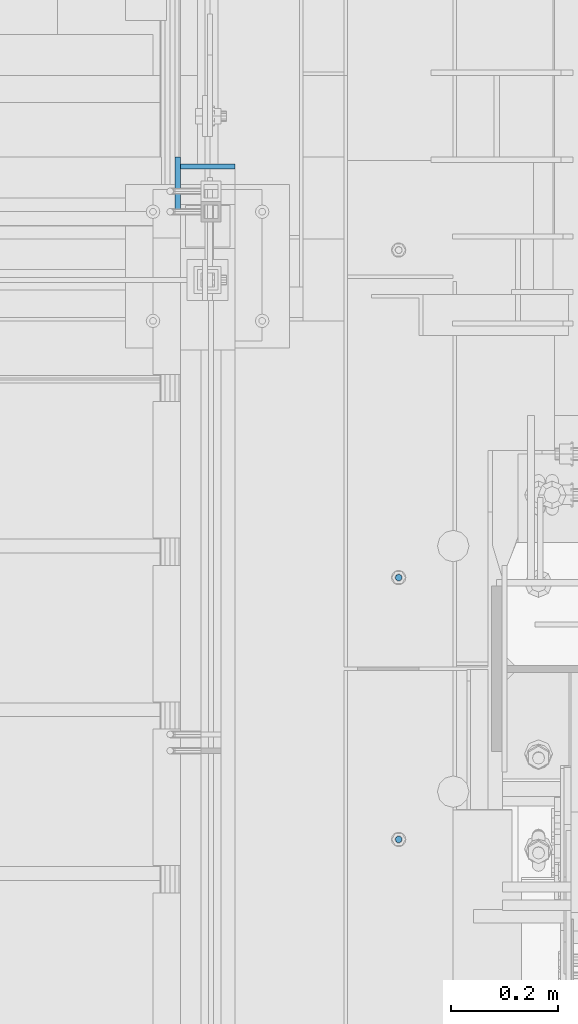
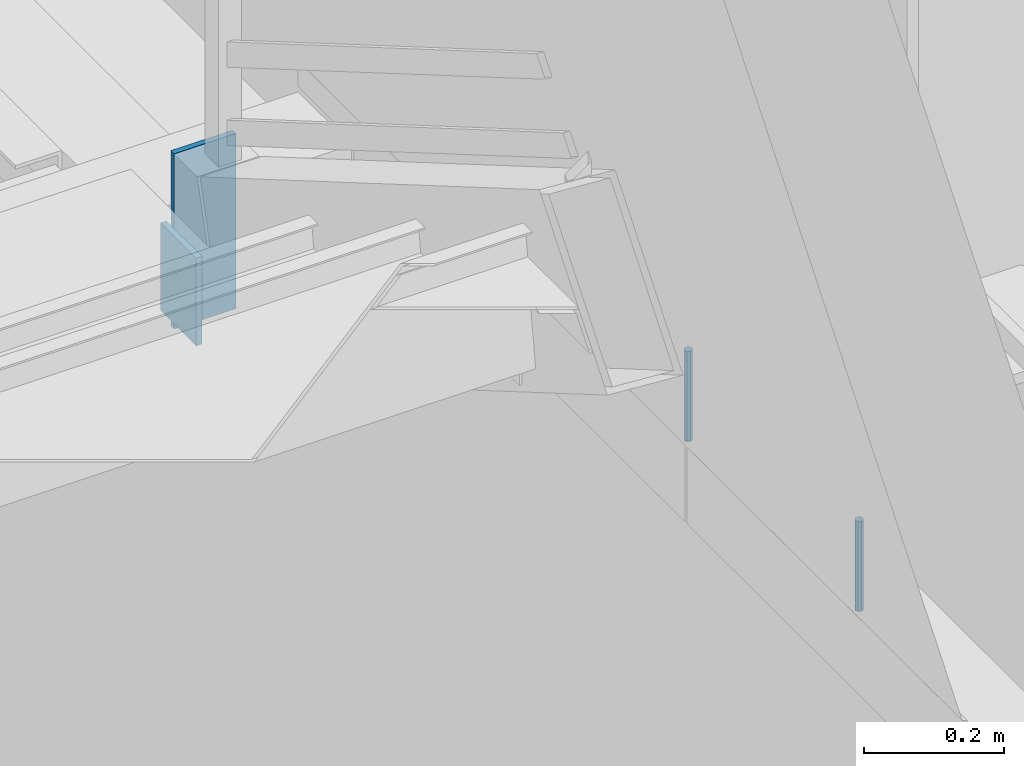
# One storey, part 491 of 1179: 4 columns, 4 elements without a shape of their own.
"""IFC2X3 building model written with IfcOpenShell, lengths in millimetres."""

from ifc_helpers import new_model, si_unit, frame, origin_with_axes, place, context, subcontext, project, spatial, faceted_brep, material, type_object, element, aggregate, save


model = new_model("IFC2X3")

# Units and contexts
model_context = context("Model", 3, precision=1e-05, world=origin_with_axes())
body_context = subcontext(model_context, "Body", "Model", "MODEL_VIEW")
ifc_project = project(units=[si_unit("LENGTHUNIT", "METRE", prefix="MILLI"), si_unit("AREAUNIT", "SQUARE_METRE"), si_unit("VOLUMEUNIT", "CUBIC_METRE"), si_unit("MASSUNIT", "GRAM", prefix="KILO"), si_unit("TIMEUNIT", "SECOND"), si_unit("PLANEANGLEUNIT", "RADIAN"), si_unit("SOLIDANGLEUNIT", "STERADIAN"), si_unit("THERMODYNAMICTEMPERATUREUNIT", "DEGREE_CELSIUS"), si_unit("LUMINOUSINTENSITYUNIT", "LUMEN")], contexts=[model_context])

# Site, building, storey
site_placement = place(None, origin_with_axes())
site = spatial("IfcSite", under=ifc_project, at=site_placement, CompositionType="ELEMENT")
building_placement = place(site_placement, origin_with_axes())
building = spatial("IfcBuilding", under=site, at=building_placement, Name="Undefined", CompositionType="ELEMENT")
storey_placement = place(building_placement, origin_with_axes())
storey = spatial("IfcBuildingStorey", under=building, at=storey_placement, Name="Undefined", CompositionType="ELEMENT", Elevation=0.0)

# Assembly, column
assembly_1_placement = place(storey_placement, origin_with_axes())
assembly_1 = element("IfcElementAssembly", 1, at=assembly_1_placement, inside=storey, Name="BEAM", AssemblyPlace="NOTDEFINED", PredefinedType="RIGID_FRAME")
ifc_material_1 = material(Name="STEEL/A36")
column_type_1 = type_object("IfcColumnType", PredefinedType="NOTDEFINED")
column_1_placement = place(assembly_1_placement, frame((-309.562499975601, 35293.3000000027, 4003.67499999882), z_axis=(0.0, 1.0, 0.0), x_axis=(0.0, 0.0, 1.0)))
column_1 = element("IfcColumn", 2, at=column_1_placement, type_object=column_type_1, material=ifc_material_1, Name="PLATE", context=body_context, shape_type="Brep", body=[
    faceted_brep([(0.0, 4.76249999999982, -50.7999999999993), (0.0, 4.76249999999982, 50.7999999999993), (152.399999999999, 4.76249999999999, 50.8000000000029), (152.399999999999, 4.76249999999999, -50.8000000000029), (0.0, -4.76249999999982, 50.7999999999993), (152.399999999999, -4.76249999999999, 50.8000000000029), (0.0, -4.76249999999982, -50.7999999999993), (152.399999999999, -4.76249999999999, -50.8000000000029)], [[[0, 1, 2, 3]], [[1, 4, 5, 2]], [[4, 6, 7, 5]], [[6, 0, 3, 7]], [[5, 7, 3, 2]], [[6, 4, 1, 0]]]),
])
aggregate(assembly_1, [column_1])

assembly_2_placement = place(storey_placement, origin_with_axes())
assembly_2 = element("IfcElementAssembly", 3, at=assembly_2_placement, inside=storey, Name="STRINGER", AssemblyPlace="NOTDEFINED", PredefinedType="RIGID_FRAME")
column_2_placement = place(assembly_2_placement, frame((-253.999999998673, 35326.6375000028, 3981.4499989016), z_axis=(1.0, 0.0, 0.0), x_axis=(0.0, 0.0, 1.0)))
column_2 = element("IfcColumn", 4, at=column_2_placement, type_object=column_type_1, material=ifc_material_1, Name="PLATE", context=body_context, shape_type="Brep", body=[
    faceted_brep([(0.0, 4.76249999999982, -50.7999999999993), (0.0, 4.76249999999982, 50.7999999999993), (304.799999999999, 4.76249999999709, 50.8), (304.799999999999, 4.76249999999709, -50.8), (0.0, -4.76249999999982, 50.7999999999993), (304.799999999999, -4.76249999999709, 50.8), (0.0, -4.76249999999982, -50.7999999999993), (304.799999999999, -4.76249999999709, -50.8)], [[[0, 1, 2, 3]], [[1, 4, 5, 2]], [[4, 6, 7, 5]], [[6, 0, 3, 7]], [[5, 7, 3, 2]], [[6, 4, 1, 0]]]),
])
aggregate(assembly_2, [column_2])

assembly_3_placement = place(storey_placement, origin_with_axes())
assembly_3 = element("IfcElementAssembly", 5, at=assembly_3_placement, inside=storey, Name="BEAM", AssemblyPlace="NOTDEFINED", PredefinedType="RIGID_FRAME")
ifc_material_2 = material(Name="STEEL/A307")
column_type_2 = type_object("IfcColumnType", PredefinedType="NOTDEFINED")
column_3_placement = place(assembly_3_placement, frame((101.600000333522, 34561.4624998706, 4108.45), z_axis=(0.0, 1.0, 0.0), x_axis=(0.0, 0.0, 1.0)))
column_3 = element("IfcColumn", 6, at=column_3_placement, type_object=column_type_2, material=ifc_material_2, Name="THREADED ROD", context=body_context, shape_type="Brep", body=[
    faceted_brep([(0.0, -6.34999999999854, 0.0), (0.0, -4.49012806053361, -4.49012806053452), (157.162499999999, -4.49012806053361, -4.49012806053361), (157.162499999999, -6.34999999999854, 0.0), (0.0, 0.0, -6.34999999999991), (157.162499999999, 0.0, -6.34999999999854), (0.0, 4.49012806053361, -4.49012806053452), (157.162499999999, 4.49012806053361, -4.49012806053361), (0.0, 6.34999999999854, 0.0), (157.162499999999, 6.34999999999854, 0.0), (0.0, 4.49012806053361, 4.49012806053452), (157.162499999999, 4.49012806053361, 4.49012806053361), (0.0, 0.0, 6.34999999999991), (157.162499999999, 0.0, 6.34999999999854), (0.0, -4.49012806053361, 4.49012806053452), (157.162499999999, -4.49012806053361, 4.49012806053361)], [[[0, 1, 2, 3]], [[1, 4, 5, 2]], [[4, 6, 7, 5]], [[6, 8, 9, 7]], [[8, 10, 11, 9]], [[10, 12, 13, 11]], [[12, 14, 15, 13]], [[14, 0, 3, 15]], [[5, 7, 9, 11, 13, 15, 3, 2]], [[14, 12, 10, 8, 6, 4, 1, 0]]]),
])
aggregate(assembly_3, [column_3])

assembly_4_placement = place(storey_placement, origin_with_axes())
assembly_4 = element("IfcElementAssembly", 7, at=assembly_4_placement, inside=storey, Name="BEAM", AssemblyPlace="NOTDEFINED", PredefinedType="RIGID_FRAME")
column_4_placement = place(assembly_4_placement, frame((101.599999999999, 34074.10025, 4108.45), z_axis=(0.0, 1.0, 0.0), x_axis=(0.0, 0.0, 1.0)))
column_4 = element("IfcColumn", 8, at=column_4_placement, type_object=column_type_2, material=ifc_material_2, Name="THREADED ROD", context=body_context, shape_type="Brep", body=[
    faceted_brep([(0.0, -6.34999999999854, 0.0), (0.0, -4.49012806053361, -4.49012806053452), (157.162499999999, -4.49012806053361, -4.49012806053361), (157.162499999999, -6.34999999999854, 0.0), (0.0, 0.0, -6.34999999999991), (157.162499999999, 0.0, -6.34999999999854), (0.0, 4.49012806053361, -4.49012806053452), (157.162499999999, 4.49012806053361, -4.49012806053361), (0.0, 6.34999999999854, 0.0), (157.162499999999, 6.34999999999854, 0.0), (0.0, 4.49012806053361, 4.49012806053452), (157.162499999999, 4.49012806053361, 4.49012806053361), (0.0, 0.0, 6.34999999999991), (157.162499999999, 0.0, 6.34999999999854), (0.0, -4.49012806053361, 4.49012806053452), (157.162499999999, -4.49012806053361, 4.49012806053361)], [[[0, 1, 2, 3]], [[1, 4, 5, 2]], [[4, 6, 7, 5]], [[6, 8, 9, 7]], [[8, 10, 11, 9]], [[10, 12, 13, 11]], [[12, 14, 15, 13]], [[14, 0, 3, 15]], [[5, 7, 9, 11, 13, 15, 3, 2]], [[14, 12, 10, 8, 6, 4, 1, 0]]]),
])
aggregate(assembly_4, [column_4])

save(model, "model.ifc")
